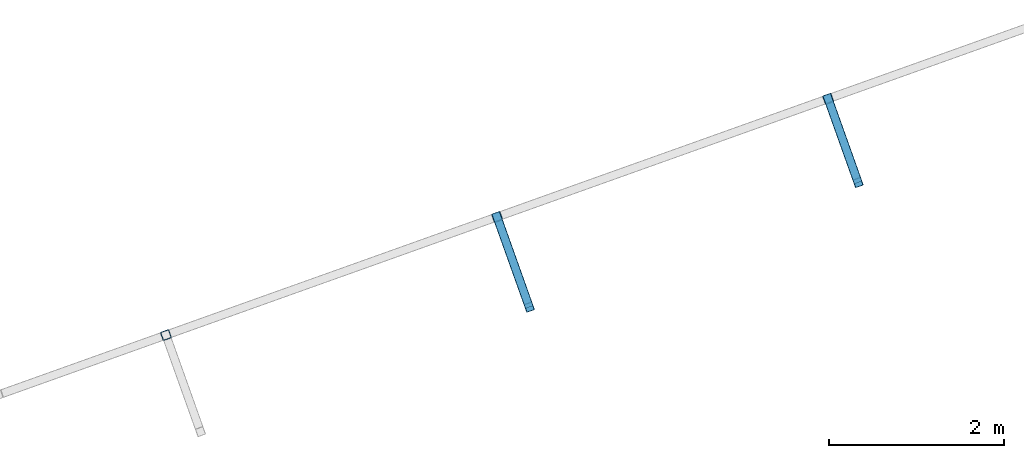
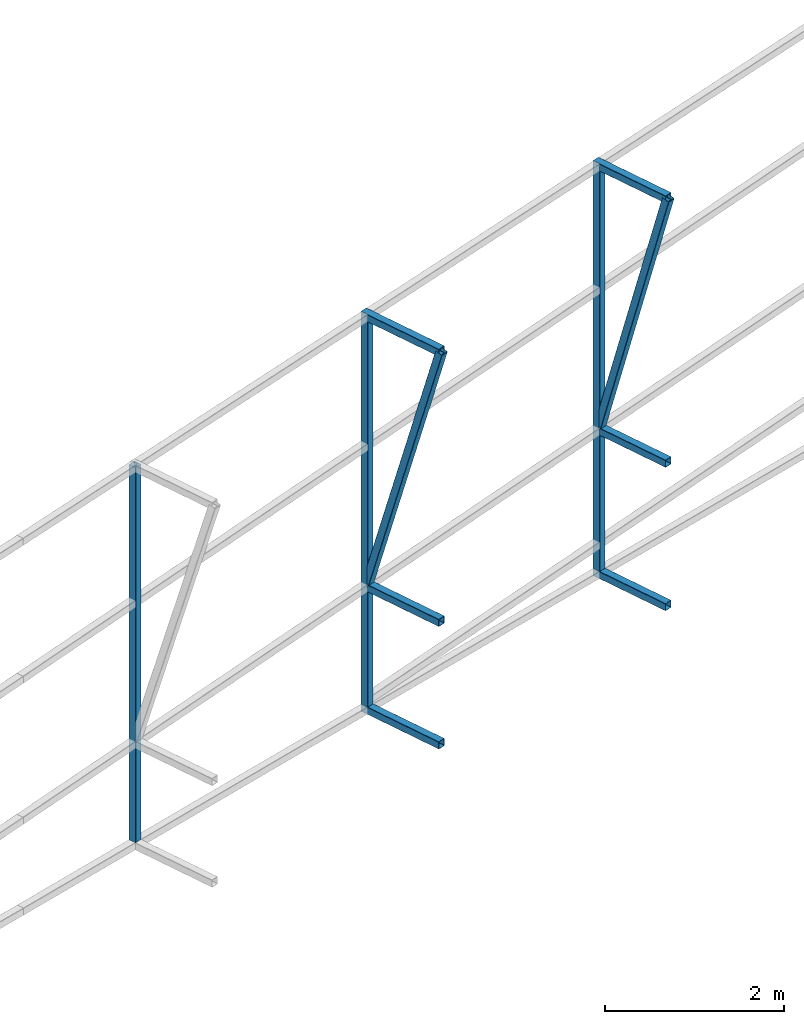
# One storey, part 128 of 215: 9 beams, 2 members, 11 elements without a shape of their own.
"""IFC2X3 building model written with IfcOpenShell, lengths in millimetres."""

import ifcopenshell
import ifcopenshell.guid

model = None  # the IFC model being written
_history = None  # IfcOwnerHistory: only IFC2X3 demands one
_inside = {}  # id of a spatial element -> (the spatial element, [elements in it])
_under = {}  # id of a project, library or spatial element -> (it, [spatial elements below it])
_declared = {}  # id of a project -> (the project, [libraries it declares])
_typed = {}  # id of a type object -> (the type object, [elements of that type])
_made_of = {}  # id of a material, layer set ... -> (it, [elements and type objects made of it])


def new_model(schema):
    """Start an empty IFC model of exactly this schema.

    Asked for "IFC4X3", IfcOpenShell would pick the latest addendum, in which some entities
    have other attributes; the version numbers below select the first issue.
    IFC2X3 requires an IfcOwnerHistory on every rooted entity: one is made here for all.
    """
    global model, _history
    if schema == "IFC4X3":
        model = ifcopenshell.file(schema_version=(4, 3, 0, 0))
    else:
        model = ifcopenshell.file(schema=schema)
    _inside.clear()
    _under.clear()
    _declared.clear()
    _typed.clear()
    _made_of.clear()
    _history = None
    if model.schema == "IFC2X3":
        org = make("IfcOrganization", Name="unknown")
        user = make(
            "IfcPersonAndOrganization",
            ThePerson=make("IfcPerson", FamilyName="unknown"),
            TheOrganization=org,
        )
        app = make(
            "IfcApplication",
            ApplicationDeveloper=org,
            Version="unknown",
            ApplicationFullName="unknown",
            ApplicationIdentifier="unknown",
        )
        _history = make(
            "IfcOwnerHistory",
            OwningUser=user,
            OwningApplication=app,
            ChangeAction="ADDED",
            CreationDate=0,
        )
    return model


def make(cls, **values):
    """One entity of the class cls with the attributes given. An attribute that is None is left unset."""
    return model.create_entity(
        cls, **{name: value for name, value in values.items() if value is not None}
    )


def rooted(cls, **values):
    """An entity with a GlobalId (a new one), such as an element, a storey or a relation."""
    return make(cls, GlobalId=ifcopenshell.guid.new(), OwnerHistory=_history, **values)


def si_unit(unit_type, name, prefix=None):
    """IfcSIUnit, for example si_unit("LENGTHUNIT", "METRE", prefix="MILLI")."""
    return make("IfcSIUnit", UnitType=unit_type, Prefix=prefix, Name=name)


def assignment(units):
    """IfcUnitAssignment: the units of a project."""
    return None if units is None else make("IfcUnitAssignment", Units=units)


def point(xyz):
    """IfcCartesianPoint."""
    return None if xyz is None else make("IfcCartesianPoint", Coordinates=xyz)


def direction(xyz):
    """IfcDirection."""
    return None if xyz is None else make("IfcDirection", DirectionRatios=xyz)


def frame(location, z_axis=None, x_axis=None):
    """IfcAxis2Placement3D, a coordinate frame: its origin and axes. An axis left out is left unset."""
    return make(
        "IfcAxis2Placement3D",
        Location=point(location),
        Axis=direction(z_axis),
        RefDirection=direction(x_axis),
    )


def frame_2d(location, x_axis=None):
    """IfcAxis2Placement2D, a coordinate frame in the plane: its origin and x axis."""
    return make(
        "IfcAxis2Placement2D", Location=point(location), RefDirection=direction(x_axis)
    )


def origin_with_axes():
    """The frame at (0, 0, 0) with the z axis (0, 0, 1) and the x axis (1, 0, 0) written out."""
    return frame((0.0, 0.0, 0.0), z_axis=(0.0, 0.0, 1.0), x_axis=(1.0, 0.0, 0.0))


def origin_2d_with_axis():
    """The frame at (0, 0) in the plane with the x axis (1, 0) written out."""
    return frame_2d((0.0, 0.0), x_axis=(1.0, 0.0))


def place(relative_to, where):
    """IfcLocalPlacement: puts the frame where relative to a parent placement (None: the world)."""
    return make(
        "IfcLocalPlacement", PlacementRelTo=relative_to, RelativePlacement=where
    )


def context(
    kind, dimensions, precision=None, world=None, true_north=None, identifier=None
):
    """IfcGeometricRepresentationContext, for example the 3D "Model" context."""
    return make(
        "IfcGeometricRepresentationContext",
        ContextIdentifier=identifier,
        ContextType=kind,
        CoordinateSpaceDimension=dimensions,
        Precision=precision,
        WorldCoordinateSystem=world,
        TrueNorth=true_north,
    )


def subcontext(parent, identifier, kind, view, scale=None):
    """IfcGeometricRepresentationSubContext, for example "Body" below "Model"."""
    return make(
        "IfcGeometricRepresentationSubContext",
        ContextIdentifier=identifier,
        ContextType=kind,
        ParentContext=parent,
        TargetScale=scale,
        TargetView=view,
    )


def project(units=None, contexts=None):
    """IfcProject with its units and contexts."""
    return rooted(
        "IfcProject",
        Name="project",
        RepresentationContexts=contexts,
        UnitsInContext=assignment(units),
    )


def spatial(cls, under=None, at=None, **own):
    """A site, building, storey or space (cls), placed at a placement, below another one or the project."""
    s = rooted(cls, ObjectPlacement=at, **own)
    if under is not None:
        _under.setdefault(under.id(), (under, []))[1].append(s)
    return s


def profile(cls, at=None, kind="AREA", **sizes):
    """A parametric profile (cls). Its sizes go by their IFC names, for example OverallWidth=200.0."""
    return make(cls, ProfileType=kind, Position=at, **sizes)


def hollow_rectangle(**sizes):
    """IfcRectangleHollowProfileDef."""
    return profile("IfcRectangleHollowProfileDef", **sizes)


def extrude(swept, where, along, depth):
    """IfcExtrudedAreaSolid: the profile swept, set in the frame where, extruded along a direction by depth."""
    return make(
        "IfcExtrudedAreaSolid",
        SweptArea=swept,
        Position=where,
        ExtrudedDirection=direction(along),
        Depth=depth,
    )


def shape(context_of_items, identifier, shape_type, items):
    """IfcShapeRepresentation: the items that make up one representation, for example the "Body"."""
    return make(
        "IfcShapeRepresentation",
        ContextOfItems=context_of_items,
        RepresentationIdentifier=identifier,
        RepresentationType=shape_type,
        Items=items,
    )


def material(Name=None, Category=None):
    """IfcMaterial."""
    return make("IfcMaterial", Name=Name, Category=Category)


def made_of(thing, what):
    """Note that an element or type object is made of a material, layer set ...; save() writes the relation."""
    if what is not None:
        _made_of.setdefault(what.id(), (what, []))[1].append(thing)
    return thing


def type_object(cls, material=None, **own):
    """A type object (cls), such as IfcWallType, which elements share."""
    return made_of(rooted(cls, **own), material)


def element(
    cls,
    number,
    at=None,
    inside=None,
    cuts=None,
    type_object=None,
    material=None,
    context=None,
    identifier="Body",
    shape_type=None,
    held_by="IfcProductDefinitionShape",
    body=None,
    shapes=None,
    **own,
):
    """One element of the class cls, such as IfcWall. Its Tag is "e" and its number.

    at: its placement. inside: the storey or other place that contains it. cuts: it is an
    opening in that element (IfcRelVoidsElement). A single representation is given by context,
    identifier, shape_type and body (its items); several are given by shapes. held_by: the class
    of the entity that holds the representations. save() writes the other relations.
    """
    e = rooted(cls, Tag="e%d" % number, ObjectPlacement=at, **own)
    if body is not None:
        shapes = [shape(context, identifier, shape_type, body)]
    if shapes is not None:
        e.Representation = make(held_by, Representations=shapes)
    if inside is not None:
        _inside.setdefault(inside.id(), (inside, []))[1].append(e)
    if cuts is not None:
        rooted(
            "IfcRelVoidsElement", RelatingBuildingElement=cuts, RelatedOpeningElement=e
        )
    if type_object is not None:
        _typed.setdefault(type_object.id(), (type_object, []))[1].append(e)
    return made_of(e, material)


def aggregate(whole, parts):
    """IfcRelAggregates: a whole, such as a stair, and the parts it consists of."""
    return rooted("IfcRelAggregates", RelatingObject=whole, RelatedObjects=parts)


def save(model, path):
    """Write the relations noted so far, then the file.

    IfcRelAggregates (storeys below a building ...), IfcRelContainedInSpatialStructure (elements
    in a storey), IfcRelDefinesByType, IfcRelAssociatesMaterial and IfcRelDeclares: one each for
    every whole, place, type object, material and project.
    """
    for whole, parts in _under.values():
        aggregate(whole, parts)
    for where, things in _inside.values():
        rooted(
            "IfcRelContainedInSpatialStructure",
            RelatedElements=things,
            RelatingStructure=where,
        )
    for kind, things in _typed.values():
        rooted("IfcRelDefinesByType", RelatedObjects=things, RelatingType=kind)
    for what, things in _made_of.values():
        rooted("IfcRelAssociatesMaterial", RelatedObjects=things, RelatingMaterial=what)
    for by, libraries in _declared.values():
        rooted("IfcRelDeclares", RelatingContext=by, RelatedDefinitions=libraries)
    model.write(path)


model = new_model("IFC2X3")

# Units and contexts
model_context = context("Model", 3, precision=1e-05, world=origin_with_axes())
body_context = subcontext(model_context, "Body", "Model", "MODEL_VIEW")
ifc_project = project(units=[si_unit("LENGTHUNIT", "METRE", prefix="MILLI"), si_unit("AREAUNIT", "SQUARE_METRE"), si_unit("VOLUMEUNIT", "CUBIC_METRE"), si_unit("MASSUNIT", "GRAM", prefix="KILO"), si_unit("TIMEUNIT", "SECOND"), si_unit("PLANEANGLEUNIT", "RADIAN"), si_unit("SOLIDANGLEUNIT", "STERADIAN"), si_unit("THERMODYNAMICTEMPERATUREUNIT", "DEGREE_CELSIUS"), si_unit("LUMINOUSINTENSITYUNIT", "LUMEN")], contexts=[model_context])

# Site, building, storey
site_placement = place(None, origin_with_axes())
site = spatial("IfcSite", under=ifc_project, at=site_placement, CompositionType="ELEMENT")
building_placement = place(site_placement, origin_with_axes())
building = spatial("IfcBuilding", under=site, at=building_placement, Name="Undefined", CompositionType="ELEMENT")
storey_placement = place(building_placement, origin_with_axes())
storey = spatial("IfcBuildingStorey", under=building, at=storey_placement, Name="Undefined", CompositionType="ELEMENT", Elevation=0.0)

# Assembly, beam
assembly_1_placement = place(storey_placement, origin_with_axes())
assembly_1 = element("IfcElementAssembly", 1, at=assembly_1_placement, inside=storey, Name="Steel Assembly", AssemblyPlace="NOTDEFINED", PredefinedType="RIGID_FRAME")
ifc_material = material(Name="STEEL/S275JR")
beam_type = type_object("IfcBeamType", PredefinedType="NOTDEFINED")
beam_1_placement = place(assembly_1_placement, frame((101549.780598652, 74827.487291154, 7046.3320392959), z_axis=(0.941802170974673, 0.33616762299096, 0.0), x_axis=(0.0, 0.0, -1.0)))
beam_1 = element("IfcBeam", 2, at=beam_1_placement, type_object=beam_type, material=ifc_material, Name="LISSE", context=body_context, shape_type="SweptSolid", body=[
    extrude(hollow_rectangle(XDim=100.0, YDim=100.0, WallThickness=4.0, InnerFilletRadius=4.0, OuterFilletRadius=8.0, at=origin_2d_with_axis()), frame((5122.27254699975, 0.0, -1.45519152278372e-11), z_axis=(-1.0, 0.0, 0.0), x_axis=(-6.93889390390723e-18, -1.0, -3.46944695195361e-18)), (0.0, 0.0, 1.0), 5122.3),
])
aggregate(assembly_1, [beam_1])

assembly_2_placement = place(storey_placement, origin_with_axes())
assembly_2 = element("IfcElementAssembly", 3, at=assembly_2_placement, inside=storey, Name="Steel Assembly", AssemblyPlace="NOTDEFINED", PredefinedType="RIGID_FRAME")
beam_2_placement = place(assembly_2_placement, frame((105693.761481801, 75145.2385298846, 1587.08846091949), z_axis=(0.941802170974673, 0.33616762299096, 0.0), x_axis=(-0.336167626855526, 0.941802169595252, 0.0)))
beam_2 = element("IfcBeam", 4, at=beam_2_placement, type_object=beam_type, material=ifc_material, Name="LISSE", context=body_context, shape_type="SweptSolid", body=[
    extrude(hollow_rectangle(XDim=100.0, YDim=100.0, WallThickness=4.0, InnerFilletRadius=4.0, OuterFilletRadius=8.0, at=origin_2d_with_axis()), frame((1143.79113414873, -2.27373675443232e-13, 0.0), z_axis=(-1.0, 0.0, 0.0), x_axis=(-6.93889390390723e-18, -1.0, -3.46944695195361e-18)), (0.0, 0.0, 1.0), 1143.8),
])
aggregate(assembly_2, [beam_2])

assembly_3_placement = place(storey_placement, origin_with_axes())
assembly_3 = element("IfcElementAssembly", 5, at=assembly_3_placement, inside=storey, Name="Steel Assembly", AssemblyPlace="NOTDEFINED", PredefinedType="RIGID_FRAME")
beam_3_placement = place(assembly_3_placement, frame((105693.76147549, 75145.2385289912, 3259.9979099935), z_axis=(0.941802170974673, 0.33616762299096, 0.0), x_axis=(-0.336167626855526, 0.941802169595252, 0.0)))
beam_3 = element("IfcBeam", 6, at=beam_3_placement, type_object=beam_type, material=ifc_material, Name="LISSE", context=body_context, shape_type="SweptSolid", body=[
    extrude(hollow_rectangle(XDim=100.0, YDim=100.0, WallThickness=4.0, InnerFilletRadius=4.0, OuterFilletRadius=8.0, at=origin_2d_with_axis()), frame((1143.79113414873, -2.27373675443232e-13, 0.0), z_axis=(-1.0, 0.0, 0.0), x_axis=(-6.93889390390723e-18, -1.0, -3.46944695195361e-18)), (0.0, 0.0, 1.0), 1143.8),
])
aggregate(assembly_3, [beam_3])

assembly_4_placement = place(storey_placement, origin_with_axes())
assembly_4 = element("IfcElementAssembly", 7, at=assembly_4_placement, inside=storey, Name="Steel Assembly", AssemblyPlace="NOTDEFINED", PredefinedType="RIGID_FRAME")
beam_4_placement = place(assembly_4_placement, frame((105693.761483314, 75145.2385300913, 6949.38219523476), z_axis=(0.941802170974673, 0.33616762299096, 0.0), x_axis=(-0.336167626855526, 0.941802169595252, 0.0)))
beam_4 = element("IfcBeam", 8, at=beam_4_placement, type_object=beam_type, material=ifc_material, Name="LISSE", context=body_context, shape_type="SweptSolid", body=[
    extrude(hollow_rectangle(XDim=100.0, YDim=100.0, WallThickness=4.0, InnerFilletRadius=4.0, OuterFilletRadius=8.0, at=origin_2d_with_axis()), frame((1143.79113414873, -2.27373675443232e-13, 0.0), z_axis=(-1.0, 0.0, 0.0), x_axis=(-6.93889390390723e-18, -1.0, -3.46944695195361e-18)), (0.0, 0.0, 1.0), 1143.8),
])
aggregate(assembly_4, [beam_4])

assembly_5_placement = place(storey_placement, origin_with_axes())
assembly_5 = element("IfcElementAssembly", 9, at=assembly_5_placement, inside=storey, Name="Steel Assembly", AssemblyPlace="NOTDEFINED", PredefinedType="RIGID_FRAME")
beam_5_placement = place(assembly_5_placement, frame((105326.064313334, 76175.3733936216, 6965.46498299538), z_axis=(0.941802170974673, 0.33616762299096, 0.0), x_axis=(0.0, 0.0, -1.0)))
beam_5 = element("IfcBeam", 10, at=beam_5_placement, type_object=beam_type, material=ifc_material, Name="LISSE", context=body_context, shape_type="SweptSolid", body=[
    extrude(hollow_rectangle(XDim=100.0, YDim=100.0, WallThickness=4.0, InnerFilletRadius=4.0, OuterFilletRadius=8.0, at=origin_2d_with_axis()), frame((5328.04343540098, -7.27595761418343e-12, -1.45519152283669e-11), z_axis=(-1.0, 0.0, 0.0), x_axis=(-6.93889390390723e-18, -1.0, -3.46944695195361e-18)), (0.0, 0.0, 1.0), 5328.0),
])
aggregate(assembly_5, [beam_5])

assembly_6_placement = place(storey_placement, origin_with_axes())
assembly_6 = element("IfcElementAssembly", 11, at=assembly_6_placement, inside=storey, Name="Steel Assembly", AssemblyPlace="NOTDEFINED", PredefinedType="RIGID_FRAME")
beam_6_placement = place(assembly_6_placement, frame((109443.821783008, 76566.591755429, 1300.45051621663), z_axis=(0.941802170974673, 0.33616762299096, 0.0), x_axis=(-0.336167626855526, 0.941802169595252, 0.0)))
beam_6 = element("IfcBeam", 12, at=beam_6_placement, type_object=beam_type, material=ifc_material, Name="LISSE", context=body_context, shape_type="SweptSolid", body=[
    extrude(hollow_rectangle(XDim=100.0, YDim=100.0, WallThickness=4.0, InnerFilletRadius=4.0, OuterFilletRadius=8.0, at=origin_2d_with_axis()), frame((1065.78417550693, 0.0, 0.0), z_axis=(-1.0, 0.0, 0.0), x_axis=(-6.93889390390723e-18, -1.0, -3.46944695195361e-18)), (0.0, 0.0, 1.0), 1065.8),
])
aggregate(assembly_6, [beam_6])

assembly_7_placement = place(storey_placement, origin_with_axes())
assembly_7 = element("IfcElementAssembly", 13, at=assembly_7_placement, inside=storey, Name="Steel Assembly", AssemblyPlace="NOTDEFINED", PredefinedType="RIGID_FRAME")
beam_7_placement = place(assembly_7_placement, frame((109443.821776989, 76566.5917545774, 3259.9979099935), z_axis=(0.941802170974673, 0.33616762299096, 0.0), x_axis=(-0.336167626855526, 0.941802169595252, 0.0)))
beam_7 = element("IfcBeam", 14, at=beam_7_placement, type_object=beam_type, material=ifc_material, Name="LISSE", context=body_context, shape_type="SweptSolid", body=[
    extrude(hollow_rectangle(XDim=100.0, YDim=100.0, WallThickness=4.0, InnerFilletRadius=4.0, OuterFilletRadius=8.0, at=origin_2d_with_axis()), frame((1065.78417550693, 0.0, 0.0), z_axis=(-1.0, 0.0, 0.0), x_axis=(-6.93889390390723e-18, -1.0, -3.46944695195361e-18)), (0.0, 0.0, 1.0), 1065.8),
])
aggregate(assembly_7, [beam_7])

assembly_8_placement = place(storey_placement, origin_with_axes())
assembly_8 = element("IfcElementAssembly", 15, at=assembly_8_placement, inside=storey, Name="Steel Assembly", AssemblyPlace="NOTDEFINED", PredefinedType="RIGID_FRAME")
beam_8_placement = place(assembly_8_placement, frame((109443.821784326, 76566.5917556079, 6868.49479494987), z_axis=(0.941802170974673, 0.33616762299096, 0.0), x_axis=(-0.336167626855526, 0.941802169595252, 0.0)))
beam_8 = element("IfcBeam", 16, at=beam_8_placement, type_object=beam_type, material=ifc_material, Name="LISSE", context=body_context, shape_type="SweptSolid", body=[
    extrude(hollow_rectangle(XDim=100.0, YDim=100.0, WallThickness=4.0, InnerFilletRadius=4.0, OuterFilletRadius=8.0, at=origin_2d_with_axis()), frame((1065.78417550693, 0.0, 0.0), z_axis=(-1.0, 0.0, 0.0), x_axis=(-6.93889390390723e-18, -1.0, -3.46944695195361e-18)), (0.0, 0.0, 1.0), 1065.8),
])
aggregate(assembly_8, [beam_8])

assembly_9_placement = place(storey_placement, origin_with_axes())
assembly_9 = element("IfcElementAssembly", 17, at=assembly_9_placement, inside=storey, Name="Steel Assembly", AssemblyPlace="NOTDEFINED", PredefinedType="RIGID_FRAME")
beam_9_placement = place(assembly_9_placement, frame((109102.348028016, 77523.2594960893, 6884.57758271151), z_axis=(0.941802170974673, 0.33616762299096, 0.0), x_axis=(0.0, 0.0, -1.0)))
beam_9 = element("IfcBeam", 18, at=beam_9_placement, type_object=beam_type, material=ifc_material, Name="LISSE", context=body_context, shape_type="SweptSolid", body=[
    extrude(hollow_rectangle(XDim=100.0, YDim=100.0, WallThickness=4.0, InnerFilletRadius=4.0, OuterFilletRadius=8.0, at=origin_2d_with_axis()), frame((5533.79397981895, 7.27595761532779e-12, 2.86090443373056e-22), z_axis=(-1.0, 0.0, 0.0), x_axis=(-6.93889390390723e-18, -1.0, -3.46944695195361e-18)), (0.0, 0.0, 1.0), 5533.8),
])
aggregate(assembly_9, [beam_9])

# Assembly, member
assembly_10_placement = place(storey_placement, origin_with_axes())
assembly_10 = element("IfcElementAssembly", 19, at=assembly_10_placement, inside=storey, Name="Steel Assembly", AssemblyPlace="NOTDEFINED", PredefinedType="RIGID_FRAME")
member_type = type_object("IfcMemberType", PredefinedType="NOTDEFINED")
member_1_placement = place(assembly_10_placement, frame((105693.761483314, 75145.2385300913, 6949.38219523476), z_axis=(0.941802170974673, 0.33616762299096, 0.0), x_axis=(-0.0955527160304239, 0.267699049085232, -0.958752782305257)))
member_1 = element("IfcMember", 20, at=member_1_placement, type_object=member_type, material=ifc_material, Name="LISSE", context=body_context, shape_type="SweptSolid", body=[
    extrude(hollow_rectangle(XDim=100.0, YDim=100.0, WallThickness=4.0, InnerFilletRadius=4.0, OuterFilletRadius=8.0, at=origin_2d_with_axis()), frame((3848.10803506584, -1.47655281354556e-11, 1.45917316354711e-11), z_axis=(-1.0, 0.0, 0.0), x_axis=(-6.93889390390723e-18, -1.0, -3.46944695195361e-18)), (0.0, 0.0, 1.0), 3848.1),
])
aggregate(assembly_10, [member_1])

assembly_11_placement = place(storey_placement, origin_with_axes())
assembly_11 = element("IfcElementAssembly", 21, at=assembly_11_placement, inside=storey, Name="Steel Assembly", AssemblyPlace="NOTDEFINED", PredefinedType="RIGID_FRAME")
member_2_placement = place(assembly_11_placement, frame((109443.821784326, 76566.5917556079, 6868.49479494987), z_axis=(0.941802170974673, 0.33616762299096, 0.0), x_axis=(-0.0910902250178651, 0.255197001050046, -0.962588729188773)))
member_2 = element("IfcMember", 22, at=member_2_placement, type_object=member_type, material=ifc_material, Name="LISSE", context=body_context, shape_type="SweptSolid", body=[
    extrude(hollow_rectangle(XDim=100.0, YDim=100.0, WallThickness=4.0, InnerFilletRadius=4.0, OuterFilletRadius=8.0, at=origin_2d_with_axis()), frame((3748.74209036232, -1.43438182392618e-11, 1.09508670396379e-13), z_axis=(-1.0, 0.0, 0.0), x_axis=(-6.93889390390723e-18, -1.0, -3.46944695195361e-18)), (0.0, 0.0, 1.0), 3748.7),
])
aggregate(assembly_11, [member_2])

save(model, "model.ifc")
